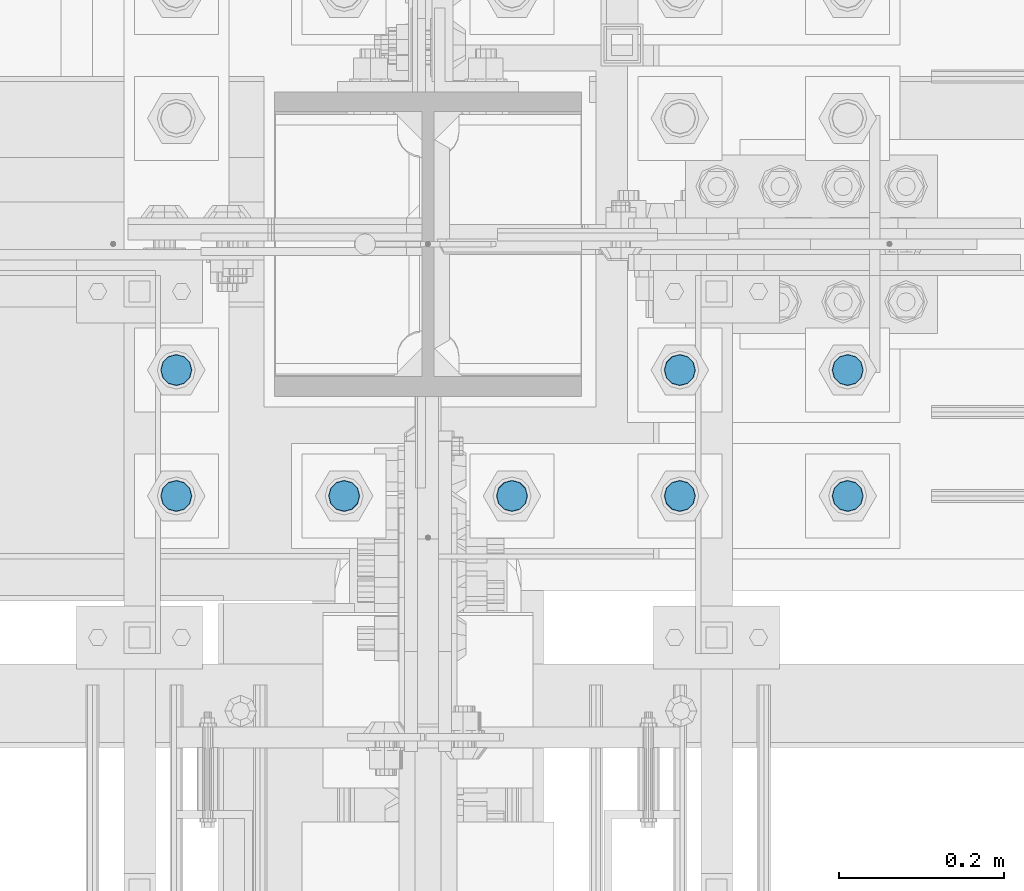
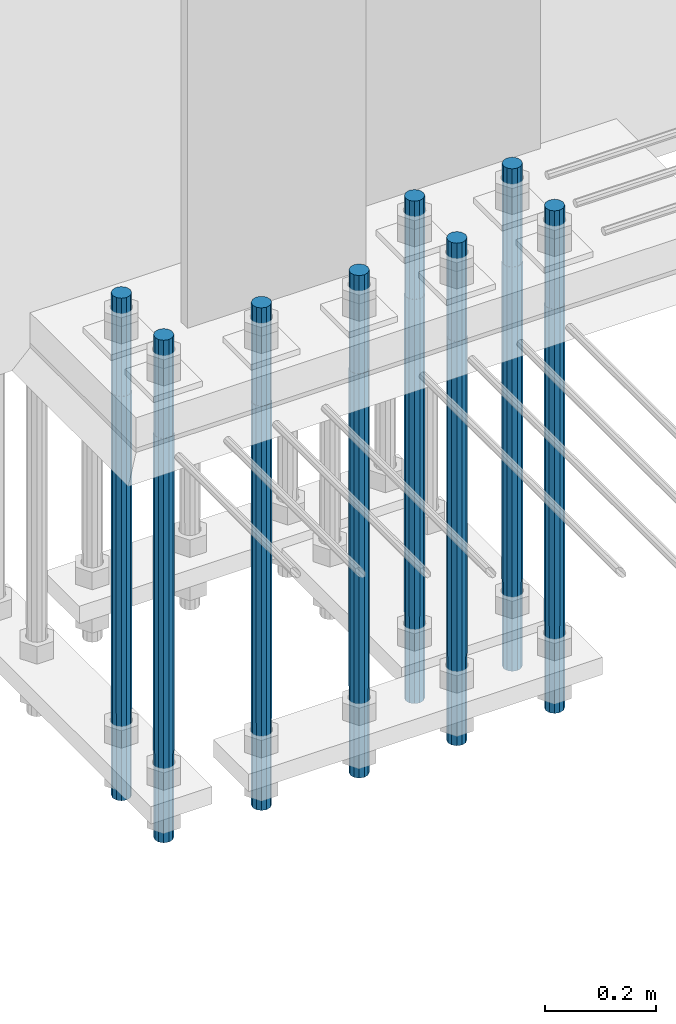
# One storey, part 1305 of 3843: 8 columns, 1 element without a shape of its own.
"""IFC2X3 building model written with IfcOpenShell, lengths in millimetres."""

from ifc_helpers import new_model, si_unit, frame, origin_with_axes, place, context, subcontext, project, spatial, faceted_brep, material, type_object, element, aggregate, save


model = new_model("IFC2X3")

# Units and contexts
model_context = context("Model", 3, precision=1e-05, world=origin_with_axes())
body_context = subcontext(model_context, "Body", "Model", "MODEL_VIEW")
ifc_project = project(units=[si_unit("LENGTHUNIT", "METRE", prefix="MILLI"), si_unit("AREAUNIT", "SQUARE_METRE"), si_unit("VOLUMEUNIT", "CUBIC_METRE"), si_unit("MASSUNIT", "GRAM", prefix="KILO"), si_unit("TIMEUNIT", "SECOND"), si_unit("PLANEANGLEUNIT", "RADIAN"), si_unit("SOLIDANGLEUNIT", "STERADIAN"), si_unit("THERMODYNAMICTEMPERATUREUNIT", "DEGREE_CELSIUS"), si_unit("LUMINOUSINTENSITYUNIT", "LUMEN")], contexts=[model_context])

# Site, building, storey
site_placement = place(None, origin_with_axes())
site = spatial("IfcSite", under=ifc_project, at=site_placement, CompositionType="ELEMENT")
building_placement = place(site_placement, origin_with_axes())
building = spatial("IfcBuilding", under=site, at=building_placement, Name="Undefined", CompositionType="ELEMENT")
storey_placement = place(building_placement, origin_with_axes())
storey = spatial("IfcBuildingStorey", under=building, at=storey_placement, Name="Undefined", CompositionType="ELEMENT", Elevation=0.0)

# Assembly, columns
assembly_placement = place(storey_placement, origin_with_axes())
assembly = element("IfcElementAssembly", 1, at=assembly_placement, inside=storey, Name="TEMPLATE", AssemblyPlace="NOTDEFINED", PredefinedType="RIGID_FRAME")
ifc_material = material(Name="Undefined/F1554-GR.55")
column_type = type_object("IfcColumnType", PredefinedType="NOTDEFINED")
column_1_placement = place(assembly_placement, frame((55626.0, 25311.1, 29565.6), z_axis=(0.0, -1.0, 0.0), x_axis=(0.0, 0.0, -1.0)))
column_1 = element("IfcColumn", 2, at=column_1_placement, type_object=column_type, material=ifc_material, Name="ANCHOR_ROD", context=body_context, shape_type="Brep", body=[
    faceted_brep([(-215.899999999998, -16.0214699700118, 9.25), (-215.899999999998, -9.25, 16.0214699700155), (-215.899999999998, 0.0, 18.5), (-215.899999999998, 9.25, 16.0214699700155), (-215.899999999998, 16.0214699700118, 9.25), (-215.899999999998, 18.5, 0.0), (-215.899999999998, 16.0214699700118, -9.25), (-215.899999999998, 9.25, -16.0214699700155), (-215.899999999998, 0.0, -18.5), (-215.899999999998, -9.25, -16.0214699700155), (-215.899999999998, -16.0214699700118, -9.25), (-215.899999999998, -18.5, 0.0), (0.0, 18.5, 0.0), (0.0, 16.0214699700118, -9.25), (0.0, 9.25, -16.0214699700155), (0.0, 0.0, -18.5), (0.0, -9.25, -16.0214699700155), (0.0, -16.0214699700118, -9.25), (0.0, -18.5, 0.0), (0.0, -16.0214699700118, 9.25), (0.0, -9.25, 16.0214699700155), (0.0, 0.0, 18.5), (0.0, 9.25, 16.0214699700155), (0.0, 16.0214699700118, 9.25), (0.0, -16.4977839420972, 9.52500000000146), (0.0, -9.52500000000146, 16.4977839420972), (0.0, 0.0, 19.0499989999989), (0.0, 9.52500000000146, 16.4977839420972), (0.0, 16.4977839420972, 9.52500000000146), (0.0, 19.0500000000029, 0.0), (0.0, 16.4977839420972, -9.52500000000146), (0.0, 9.52500000000146, -16.4977839420972), (0.0, 0.0, -19.0499989999989), (0.0, -9.52500000000146, -16.4977839420972), (0.0, -16.4977839420972, -9.52500000000146), (0.0, -19.0500000000029, 0.0), (698.5, -19.0499999999993, 0.0), (698.5, -16.4977839420935, 9.52499999999418), (698.5, -9.52500000000146, 16.4977839420899), (698.5, 0.0, 19.0500000000029), (698.5, 9.52500000000146, 16.4977839420899), (698.5, 16.4977839420935, 9.52499999999418), (698.5, 19.0499999999993, 0.0), (698.5, 16.4977839420935, -9.52499999999418), (698.5, 9.52500000000146, -16.4977839420899), (698.5, 0.0, -19.0500000000029), (698.5, -9.52500000000146, -16.4977839420899), (698.5, -16.4977839420935, -9.52499999999418), (698.5, -9.25, 16.0214699700155), (698.5, 0.0, 18.5), (698.5, 9.25, 16.0214699700155), (698.5, 16.0214699700118, 9.25), (698.5, 18.5, 0.0), (698.5, 16.0214699700118, -9.25), (698.5, 9.25, -16.0214699700155), (698.5, 0.0, -18.5), (698.5, -9.25, -16.0214699700155), (698.5, -16.0214699700118, -9.25), (698.5, -18.5, 0.0), (698.5, -16.0214699700118, 9.25), (889.0, -9.25, -16.0214699700155), (889.0, 0.0, -18.5), (889.0, 9.25, -16.0214699700155), (889.0, 16.0214699700118, -9.25), (889.0, 18.5, 0.0), (889.0, 16.0214699700118, 9.25), (889.0, 9.25, 16.0214699700155), (889.0, 0.0, 18.5), (889.0, -9.25, 16.0214699700155), (889.0, -16.0214699700118, 9.25), (889.0, -18.5, 0.0), (889.0, -16.0214699700118, -9.25)], [[[0, 1, 2, 3, 4, 5, 6, 7, 8, 9, 10, 11]], [[6, 5, 12, 13]], [[7, 6, 13, 14]], [[8, 7, 14, 15]], [[9, 8, 15, 16]], [[10, 9, 16, 17]], [[11, 10, 17, 18]], [[0, 11, 18, 19]], [[1, 0, 19, 20]], [[2, 1, 20, 21]], [[3, 2, 21, 22]], [[4, 3, 22, 23]], [[5, 4, 23, 12]], [[24, 25, 26, 27, 28, 29, 30, 31, 32, 33, 34, 35], [22, 21, 20, 19, 18, 17, 16, 15, 14, 13, 12, 23]], [[24, 35, 36, 37]], [[25, 24, 37, 38]], [[26, 25, 38, 39]], [[27, 26, 39, 40]], [[28, 27, 40, 41]], [[29, 28, 41, 42]], [[30, 29, 42, 43]], [[31, 30, 43, 44]], [[32, 31, 44, 45]], [[33, 32, 45, 46]], [[34, 33, 46, 47]], [[35, 34, 47, 36]], [[46, 45, 44, 43, 42, 41, 40, 39, 38, 37, 36, 47], [48, 49, 50, 51, 52, 53, 54, 55, 56, 57, 58, 59]], [[60, 61, 62, 63, 64, 65, 66, 67, 68, 69, 70, 71]], [[68, 67, 49, 48]], [[69, 68, 48, 59]], [[70, 69, 59, 58]], [[71, 70, 58, 57]], [[60, 71, 57, 56]], [[61, 60, 56, 55]], [[62, 61, 55, 54]], [[63, 62, 54, 53]], [[64, 63, 53, 52]], [[65, 64, 52, 51]], [[66, 65, 51, 50]], [[67, 66, 50, 49]]]),
])
column_2_placement = place(assembly_placement, frame((55829.2, 25311.1, 29565.6), z_axis=(0.0, -1.0, 0.0), x_axis=(0.0, 0.0, -1.0)))
column_2 = element("IfcColumn", 3, at=column_2_placement, type_object=column_type, material=ifc_material, Name="ANCHOR_ROD", context=body_context, shape_type="Brep", body=[
    faceted_brep([(-215.899999999998, -16.0214699700118, 9.25), (-215.899999999998, -9.25, 16.0214699700155), (-215.899999999998, 0.0, 18.5), (-215.899999999998, 9.25, 16.0214699700155), (-215.899999999998, 16.0214699700118, 9.25), (-215.899999999998, 18.5, 0.0), (-215.899999999998, 16.0214699700118, -9.25), (-215.899999999998, 9.25, -16.0214699700155), (-215.899999999998, 0.0, -18.5), (-215.899999999998, -9.25, -16.0214699700155), (-215.899999999998, -16.0214699700118, -9.25), (-215.899999999998, -18.5, 0.0), (0.0, 18.5, 0.0), (0.0, 16.0214699700118, -9.25), (0.0, 9.25, -16.0214699700155), (0.0, 0.0, -18.5), (0.0, -9.25, -16.0214699700155), (0.0, -16.0214699700118, -9.25), (0.0, -18.5, 0.0), (0.0, -16.0214699700118, 9.25), (0.0, -9.25, 16.0214699700155), (0.0, 0.0, 18.5), (0.0, 9.25, 16.0214699700155), (0.0, 16.0214699700118, 9.25), (0.0, -16.4977839420972, 9.52500000000146), (0.0, -9.52500000000146, 16.4977839420972), (0.0, 0.0, 19.0499989999989), (0.0, 9.52500000000146, 16.4977839420972), (0.0, 16.4977839420972, 9.52500000000146), (0.0, 19.0500000000029, 0.0), (0.0, 16.4977839420972, -9.52500000000146), (0.0, 9.52500000000146, -16.4977839420972), (0.0, 0.0, -19.0499989999989), (0.0, -9.52500000000146, -16.4977839420972), (0.0, -16.4977839420972, -9.52500000000146), (0.0, -19.0500000000029, 0.0), (698.5, -19.0499999999993, 0.0), (698.5, -16.4977839420935, 9.52499999999418), (698.5, -9.52500000000146, 16.4977839420899), (698.5, 0.0, 19.0500000000029), (698.5, 9.52500000000146, 16.4977839420899), (698.5, 16.4977839420935, 9.52499999999418), (698.5, 19.0499999999993, 0.0), (698.5, 16.4977839420935, -9.52499999999418), (698.5, 9.52500000000146, -16.4977839420899), (698.5, 0.0, -19.0500000000029), (698.5, -9.52500000000146, -16.4977839420899), (698.5, -16.4977839420935, -9.52499999999418), (698.5, -9.25, 16.0214699700155), (698.5, 0.0, 18.5), (698.5, 9.25, 16.0214699700155), (698.5, 16.0214699700118, 9.25), (698.5, 18.5, 0.0), (698.5, 16.0214699700118, -9.25), (698.5, 9.25, -16.0214699700155), (698.5, 0.0, -18.5), (698.5, -9.25, -16.0214699700155), (698.5, -16.0214699700118, -9.25), (698.5, -18.5, 0.0), (698.5, -16.0214699700118, 9.25), (889.0, -9.25, -16.0214699700155), (889.0, 0.0, -18.5), (889.0, 9.25, -16.0214699700155), (889.0, 16.0214699700118, -9.25), (889.0, 18.5, 0.0), (889.0, 16.0214699700118, 9.25), (889.0, 9.25, 16.0214699700155), (889.0, 0.0, 18.5), (889.0, -9.25, 16.0214699700155), (889.0, -16.0214699700118, 9.25), (889.0, -18.5, 0.0), (889.0, -16.0214699700118, -9.25)], [[[0, 1, 2, 3, 4, 5, 6, 7, 8, 9, 10, 11]], [[6, 5, 12, 13]], [[7, 6, 13, 14]], [[8, 7, 14, 15]], [[9, 8, 15, 16]], [[10, 9, 16, 17]], [[11, 10, 17, 18]], [[0, 11, 18, 19]], [[1, 0, 19, 20]], [[2, 1, 20, 21]], [[3, 2, 21, 22]], [[4, 3, 22, 23]], [[5, 4, 23, 12]], [[24, 25, 26, 27, 28, 29, 30, 31, 32, 33, 34, 35], [22, 21, 20, 19, 18, 17, 16, 15, 14, 13, 12, 23]], [[24, 35, 36, 37]], [[25, 24, 37, 38]], [[26, 25, 38, 39]], [[27, 26, 39, 40]], [[28, 27, 40, 41]], [[29, 28, 41, 42]], [[30, 29, 42, 43]], [[31, 30, 43, 44]], [[32, 31, 44, 45]], [[33, 32, 45, 46]], [[34, 33, 46, 47]], [[35, 34, 47, 36]], [[46, 45, 44, 43, 42, 41, 40, 39, 38, 37, 36, 47], [48, 49, 50, 51, 52, 53, 54, 55, 56, 57, 58, 59]], [[60, 61, 62, 63, 64, 65, 66, 67, 68, 69, 70, 71]], [[68, 67, 49, 48]], [[69, 68, 48, 59]], [[70, 69, 59, 58]], [[71, 70, 58, 57]], [[60, 71, 57, 56]], [[61, 60, 56, 55]], [[62, 61, 55, 54]], [[63, 62, 54, 53]], [[64, 63, 53, 52]], [[65, 64, 52, 51]], [[66, 65, 51, 50]], [[67, 66, 50, 49]]]),
])
column_3_placement = place(assembly_placement, frame((56032.4, 25311.1, 29565.6), z_axis=(0.0, -1.0, 0.0), x_axis=(0.0, 0.0, -1.0)))
column_3 = element("IfcColumn", 4, at=column_3_placement, type_object=column_type, material=ifc_material, Name="ANCHOR_ROD", context=body_context, shape_type="Brep", body=[
    faceted_brep([(-215.899999999998, -16.0214699700118, 9.25), (-215.899999999998, -9.25, 16.0214699700155), (-215.899999999998, 0.0, 18.5), (-215.899999999998, 9.25, 16.0214699700155), (-215.899999999998, 16.0214699700118, 9.25), (-215.899999999998, 18.5, 0.0), (-215.899999999998, 16.0214699700118, -9.25), (-215.899999999998, 9.25, -16.0214699700155), (-215.899999999998, 0.0, -18.5), (-215.899999999998, -9.25, -16.0214699700155), (-215.899999999998, -16.0214699700118, -9.25), (-215.899999999998, -18.5, 0.0), (0.0, 18.5, 0.0), (0.0, 16.0214699700118, -9.25), (0.0, 9.25, -16.0214699700155), (0.0, 0.0, -18.5), (0.0, -9.25, -16.0214699700155), (0.0, -16.0214699700118, -9.25), (0.0, -18.5, 0.0), (0.0, -16.0214699700118, 9.25), (0.0, -9.25, 16.0214699700155), (0.0, 0.0, 18.5), (0.0, 9.25, 16.0214699700155), (0.0, 16.0214699700118, 9.25), (0.0, -16.4977839420972, 9.52500000000146), (0.0, -9.52500000000146, 16.4977839420972), (0.0, 0.0, 19.0499989999989), (0.0, 9.52500000000146, 16.4977839420972), (0.0, 16.4977839420972, 9.52500000000146), (0.0, 19.0500000000029, 0.0), (0.0, 16.4977839420972, -9.52500000000146), (0.0, 9.52500000000146, -16.4977839420972), (0.0, 0.0, -19.0499989999989), (0.0, -9.52500000000146, -16.4977839420972), (0.0, -16.4977839420972, -9.52500000000146), (0.0, -19.0500000000029, 0.0), (698.5, -19.0499999999993, 0.0), (698.5, -16.4977839420935, 9.52499999999418), (698.5, -9.52500000000146, 16.4977839420899), (698.5, 0.0, 19.0500000000029), (698.5, 9.52500000000146, 16.4977839420899), (698.5, 16.4977839420935, 9.52499999999418), (698.5, 19.0499999999993, 0.0), (698.5, 16.4977839420935, -9.52499999999418), (698.5, 9.52500000000146, -16.4977839420899), (698.5, 0.0, -19.0500000000029), (698.5, -9.52500000000146, -16.4977839420899), (698.5, -16.4977839420935, -9.52499999999418), (698.5, -9.25, 16.0214699700155), (698.5, 0.0, 18.5), (698.5, 9.25, 16.0214699700155), (698.5, 16.0214699700118, 9.25), (698.5, 18.5, 0.0), (698.5, 16.0214699700118, -9.25), (698.5, 9.25, -16.0214699700155), (698.5, 0.0, -18.5), (698.5, -9.25, -16.0214699700155), (698.5, -16.0214699700118, -9.25), (698.5, -18.5, 0.0), (698.5, -16.0214699700118, 9.25), (889.0, -9.25, -16.0214699700155), (889.0, 0.0, -18.5), (889.0, 9.25, -16.0214699700155), (889.0, 16.0214699700118, -9.25), (889.0, 18.5, 0.0), (889.0, 16.0214699700118, 9.25), (889.0, 9.25, 16.0214699700155), (889.0, 0.0, 18.5), (889.0, -9.25, 16.0214699700155), (889.0, -16.0214699700118, 9.25), (889.0, -18.5, 0.0), (889.0, -16.0214699700118, -9.25)], [[[0, 1, 2, 3, 4, 5, 6, 7, 8, 9, 10, 11]], [[6, 5, 12, 13]], [[7, 6, 13, 14]], [[8, 7, 14, 15]], [[9, 8, 15, 16]], [[10, 9, 16, 17]], [[11, 10, 17, 18]], [[0, 11, 18, 19]], [[1, 0, 19, 20]], [[2, 1, 20, 21]], [[3, 2, 21, 22]], [[4, 3, 22, 23]], [[5, 4, 23, 12]], [[24, 25, 26, 27, 28, 29, 30, 31, 32, 33, 34, 35], [22, 21, 20, 19, 18, 17, 16, 15, 14, 13, 12, 23]], [[24, 35, 36, 37]], [[25, 24, 37, 38]], [[26, 25, 38, 39]], [[27, 26, 39, 40]], [[28, 27, 40, 41]], [[29, 28, 41, 42]], [[30, 29, 42, 43]], [[31, 30, 43, 44]], [[32, 31, 44, 45]], [[33, 32, 45, 46]], [[34, 33, 46, 47]], [[35, 34, 47, 36]], [[46, 45, 44, 43, 42, 41, 40, 39, 38, 37, 36, 47], [48, 49, 50, 51, 52, 53, 54, 55, 56, 57, 58, 59]], [[60, 61, 62, 63, 64, 65, 66, 67, 68, 69, 70, 71]], [[68, 67, 49, 48]], [[69, 68, 48, 59]], [[70, 69, 59, 58]], [[71, 70, 58, 57]], [[60, 71, 57, 56]], [[61, 60, 56, 55]], [[62, 61, 55, 54]], [[63, 62, 54, 53]], [[64, 63, 53, 52]], [[65, 64, 52, 51]], [[66, 65, 51, 50]], [[67, 66, 50, 49]]]),
])
column_4_placement = place(assembly_placement, frame((56235.6, 25311.1, 29565.6), z_axis=(0.0, 1.0, 0.0), x_axis=(0.0, 0.0, -1.0)))
column_4 = element("IfcColumn", 5, at=column_4_placement, type_object=column_type, material=ifc_material, Name="ANCHOR_ROD", context=body_context, shape_type="Brep", body=[
    faceted_brep([(-215.899999999998, -16.0214699700118, 9.25), (-215.899999999998, -9.25, 16.0214699700155), (-215.899999999998, 0.0, 18.5), (-215.899999999998, 9.25, 16.0214699700155), (-215.899999999998, 16.0214699700118, 9.25), (-215.899999999998, 18.5, 0.0), (-215.899999999998, 16.0214699700118, -9.25), (-215.899999999998, 9.25, -16.0214699700155), (-215.899999999998, 0.0, -18.5), (-215.899999999998, -9.25, -16.0214699700155), (-215.899999999998, -16.0214699700118, -9.25), (-215.899999999998, -18.5, 0.0), (0.0, 18.5, 0.0), (0.0, 16.0214699700118, -9.25), (0.0, 9.25, -16.0214699700155), (0.0, 0.0, -18.5), (0.0, -9.25, -16.0214699700155), (0.0, -16.0214699700118, -9.25), (0.0, -18.5, 0.0), (0.0, -16.0214699700118, 9.25), (0.0, -9.25, 16.0214699700155), (0.0, 0.0, 18.5), (0.0, 9.25, 16.0214699700155), (0.0, 16.0214699700118, 9.25), (0.0, -16.4977839420972, 9.52500000000146), (0.0, -9.52500000000146, 16.4977839420972), (0.0, 0.0, 19.0499989999989), (0.0, 9.52500000000146, 16.4977839420972), (0.0, 16.4977839420972, 9.52500000000146), (0.0, 19.0500000000029, 0.0), (0.0, 16.4977839420972, -9.52500000000146), (0.0, 9.52500000000146, -16.4977839420972), (0.0, 0.0, -19.0499989999989), (0.0, -9.52500000000146, -16.4977839420972), (0.0, -16.4977839420972, -9.52500000000146), (0.0, -19.0500000000029, 0.0), (698.5, -19.0499999999993, 0.0), (698.5, -16.4977839420935, 9.52499999999418), (698.5, -9.52500000000146, 16.4977839420899), (698.5, 0.0, 19.0500000000029), (698.5, 9.52500000000146, 16.4977839420899), (698.5, 16.4977839420935, 9.52499999999418), (698.5, 19.0499999999993, 0.0), (698.5, 16.4977839420935, -9.52499999999418), (698.5, 9.52500000000146, -16.4977839420899), (698.5, 0.0, -19.0500000000029), (698.5, -9.52500000000146, -16.4977839420899), (698.5, -16.4977839420935, -9.52499999999418), (698.5, -9.25, 16.0214699700155), (698.5, 0.0, 18.5), (698.5, 9.25, 16.0214699700155), (698.5, 16.0214699700118, 9.25), (698.5, 18.5, 0.0), (698.5, 16.0214699700118, -9.25), (698.5, 9.25, -16.0214699700155), (698.5, 0.0, -18.5), (698.5, -9.25, -16.0214699700155), (698.5, -16.0214699700118, -9.25), (698.5, -18.5, 0.0), (698.5, -16.0214699700118, 9.25), (889.0, -9.25, -16.0214699700155), (889.0, 0.0, -18.5), (889.0, 9.25, -16.0214699700155), (889.0, 16.0214699700118, -9.25), (889.0, 18.5, 0.0), (889.0, 16.0214699700118, 9.25), (889.0, 9.25, 16.0214699700155), (889.0, 0.0, 18.5), (889.0, -9.25, 16.0214699700155), (889.0, -16.0214699700118, 9.25), (889.0, -18.5, 0.0), (889.0, -16.0214699700118, -9.25)], [[[0, 1, 2, 3, 4, 5, 6, 7, 8, 9, 10, 11]], [[6, 5, 12, 13]], [[7, 6, 13, 14]], [[8, 7, 14, 15]], [[9, 8, 15, 16]], [[10, 9, 16, 17]], [[11, 10, 17, 18]], [[0, 11, 18, 19]], [[1, 0, 19, 20]], [[2, 1, 20, 21]], [[3, 2, 21, 22]], [[4, 3, 22, 23]], [[5, 4, 23, 12]], [[24, 25, 26, 27, 28, 29, 30, 31, 32, 33, 34, 35], [22, 21, 20, 19, 18, 17, 16, 15, 14, 13, 12, 23]], [[24, 35, 36, 37]], [[25, 24, 37, 38]], [[26, 25, 38, 39]], [[27, 26, 39, 40]], [[28, 27, 40, 41]], [[29, 28, 41, 42]], [[30, 29, 42, 43]], [[31, 30, 43, 44]], [[32, 31, 44, 45]], [[33, 32, 45, 46]], [[34, 33, 46, 47]], [[35, 34, 47, 36]], [[46, 45, 44, 43, 42, 41, 40, 39, 38, 37, 36, 47], [48, 49, 50, 51, 52, 53, 54, 55, 56, 57, 58, 59]], [[60, 61, 62, 63, 64, 65, 66, 67, 68, 69, 70, 71]], [[68, 67, 49, 48]], [[69, 68, 48, 59]], [[70, 69, 59, 58]], [[71, 70, 58, 57]], [[60, 71, 57, 56]], [[61, 60, 56, 55]], [[62, 61, 55, 54]], [[63, 62, 54, 53]], [[64, 63, 53, 52]], [[65, 64, 52, 51]], [[66, 65, 51, 50]], [[67, 66, 50, 49]]]),
])
column_5_placement = place(assembly_placement, frame((56438.8, 25311.1, 29565.6), z_axis=(0.0, 1.0, 0.0), x_axis=(0.0, 0.0, -1.0)))
column_5 = element("IfcColumn", 6, at=column_5_placement, type_object=column_type, material=ifc_material, Name="ANCHOR_ROD", context=body_context, shape_type="Brep", body=[
    faceted_brep([(-215.899999999998, -16.0214699700118, 9.25), (-215.899999999998, -9.25, 16.0214699700155), (-215.899999999998, 0.0, 18.5), (-215.899999999998, 9.25, 16.0214699700155), (-215.899999999998, 16.0214699700118, 9.25), (-215.899999999998, 18.5, 0.0), (-215.899999999998, 16.0214699700118, -9.25), (-215.899999999998, 9.25, -16.0214699700155), (-215.899999999998, 0.0, -18.5), (-215.899999999998, -9.25, -16.0214699700155), (-215.899999999998, -16.0214699700118, -9.25), (-215.899999999998, -18.5, 0.0), (0.0, 18.5, 0.0), (0.0, 16.0214699700118, -9.25), (0.0, 9.25, -16.0214699700155), (0.0, 0.0, -18.5), (0.0, -9.25, -16.0214699700155), (0.0, -16.0214699700118, -9.25), (0.0, -18.5, 0.0), (0.0, -16.0214699700118, 9.25), (0.0, -9.25, 16.0214699700155), (0.0, 0.0, 18.5), (0.0, 9.25, 16.0214699700155), (0.0, 16.0214699700118, 9.25), (0.0, -16.4977839420972, 9.52500000000146), (0.0, -9.52500000000146, 16.4977839420972), (0.0, 0.0, 19.0499989999989), (0.0, 9.52500000000146, 16.4977839420972), (0.0, 16.4977839420972, 9.52500000000146), (0.0, 19.0500000000029, 0.0), (0.0, 16.4977839420972, -9.52500000000146), (0.0, 9.52500000000146, -16.4977839420972), (0.0, 0.0, -19.0499989999989), (0.0, -9.52500000000146, -16.4977839420972), (0.0, -16.4977839420972, -9.52500000000146), (0.0, -19.0500000000029, 0.0), (698.5, -19.0499999999993, 0.0), (698.5, -16.4977839420935, 9.52499999999418), (698.5, -9.52500000000146, 16.4977839420899), (698.5, 0.0, 19.0500000000029), (698.5, 9.52500000000146, 16.4977839420899), (698.5, 16.4977839420935, 9.52499999999418), (698.5, 19.0499999999993, 0.0), (698.5, 16.4977839420935, -9.52499999999418), (698.5, 9.52500000000146, -16.4977839420899), (698.5, 0.0, -19.0500000000029), (698.5, -9.52500000000146, -16.4977839420899), (698.5, -16.4977839420935, -9.52499999999418), (698.5, -9.25, 16.0214699700155), (698.5, 0.0, 18.5), (698.5, 9.25, 16.0214699700155), (698.5, 16.0214699700118, 9.25), (698.5, 18.5, 0.0), (698.5, 16.0214699700118, -9.25), (698.5, 9.25, -16.0214699700155), (698.5, 0.0, -18.5), (698.5, -9.25, -16.0214699700155), (698.5, -16.0214699700118, -9.25), (698.5, -18.5, 0.0), (698.5, -16.0214699700118, 9.25), (889.0, -9.25, -16.0214699700155), (889.0, 0.0, -18.5), (889.0, 9.25, -16.0214699700155), (889.0, 16.0214699700118, -9.25), (889.0, 18.5, 0.0), (889.0, 16.0214699700118, 9.25), (889.0, 9.25, 16.0214699700155), (889.0, 0.0, 18.5), (889.0, -9.25, 16.0214699700155), (889.0, -16.0214699700118, 9.25), (889.0, -18.5, 0.0), (889.0, -16.0214699700118, -9.25)], [[[0, 1, 2, 3, 4, 5, 6, 7, 8, 9, 10, 11]], [[6, 5, 12, 13]], [[7, 6, 13, 14]], [[8, 7, 14, 15]], [[9, 8, 15, 16]], [[10, 9, 16, 17]], [[11, 10, 17, 18]], [[0, 11, 18, 19]], [[1, 0, 19, 20]], [[2, 1, 20, 21]], [[3, 2, 21, 22]], [[4, 3, 22, 23]], [[5, 4, 23, 12]], [[24, 25, 26, 27, 28, 29, 30, 31, 32, 33, 34, 35], [22, 21, 20, 19, 18, 17, 16, 15, 14, 13, 12, 23]], [[24, 35, 36, 37]], [[25, 24, 37, 38]], [[26, 25, 38, 39]], [[27, 26, 39, 40]], [[28, 27, 40, 41]], [[29, 28, 41, 42]], [[30, 29, 42, 43]], [[31, 30, 43, 44]], [[32, 31, 44, 45]], [[33, 32, 45, 46]], [[34, 33, 46, 47]], [[35, 34, 47, 36]], [[46, 45, 44, 43, 42, 41, 40, 39, 38, 37, 36, 47], [48, 49, 50, 51, 52, 53, 54, 55, 56, 57, 58, 59]], [[60, 61, 62, 63, 64, 65, 66, 67, 68, 69, 70, 71]], [[68, 67, 49, 48]], [[69, 68, 48, 59]], [[70, 69, 59, 58]], [[71, 70, 58, 57]], [[60, 71, 57, 56]], [[61, 60, 56, 55]], [[62, 61, 55, 54]], [[63, 62, 54, 53]], [[64, 63, 53, 52]], [[65, 64, 52, 51]], [[66, 65, 51, 50]], [[67, 66, 50, 49]]]),
])
column_6_placement = place(assembly_placement, frame((55626.0, 25463.5, 29565.6), z_axis=(0.0, -1.0, 0.0), x_axis=(0.0, 0.0, -1.0)))
column_6 = element("IfcColumn", 7, at=column_6_placement, type_object=column_type, material=ifc_material, Name="ANCHOR_ROD", context=body_context, shape_type="Brep", body=[
    faceted_brep([(-215.899999999998, -16.0214699700118, 9.25), (-215.899999999998, -9.25, 16.0214699700155), (-215.899999999998, 0.0, 18.5), (-215.899999999998, 9.25, 16.0214699700155), (-215.899999999998, 16.0214699700118, 9.25), (-215.899999999998, 18.5, 0.0), (-215.899999999998, 16.0214699700118, -9.25), (-215.899999999998, 9.25, -16.0214699700155), (-215.899999999998, 0.0, -18.5), (-215.899999999998, -9.25, -16.0214699700155), (-215.899999999998, -16.0214699700118, -9.25), (-215.899999999998, -18.5, 0.0), (0.0, 18.5, 0.0), (0.0, 16.0214699700118, -9.25), (0.0, 9.25, -16.0214699700155), (0.0, 0.0, -18.5), (0.0, -9.25, -16.0214699700155), (0.0, -16.0214699700118, -9.25), (0.0, -18.5, 0.0), (0.0, -16.0214699700118, 9.25), (0.0, -9.25, 16.0214699700155), (0.0, 0.0, 18.5), (0.0, 9.25, 16.0214699700155), (0.0, 16.0214699700118, 9.25), (0.0, -16.4977839420972, 9.52500000000146), (0.0, -9.52500000000146, 16.4977839420972), (0.0, 0.0, 19.0499989999989), (0.0, 9.52500000000146, 16.4977839420972), (0.0, 16.4977839420972, 9.52500000000146), (0.0, 19.0500000000029, 0.0), (0.0, 16.4977839420972, -9.52500000000146), (0.0, 9.52500000000146, -16.4977839420972), (0.0, 0.0, -19.0499989999989), (0.0, -9.52500000000146, -16.4977839420972), (0.0, -16.4977839420972, -9.52500000000146), (0.0, -19.0500000000029, 0.0), (698.5, -19.0499999999993, 0.0), (698.5, -16.4977839420935, 9.52499999999418), (698.5, -9.52500000000146, 16.4977839420899), (698.5, 0.0, 19.0500000000029), (698.5, 9.52500000000146, 16.4977839420899), (698.5, 16.4977839420935, 9.52499999999418), (698.5, 19.0499999999993, 0.0), (698.5, 16.4977839420935, -9.52499999999418), (698.5, 9.52500000000146, -16.4977839420899), (698.5, 0.0, -19.0500000000029), (698.5, -9.52500000000146, -16.4977839420899), (698.5, -16.4977839420935, -9.52499999999418), (698.5, -9.25, 16.0214699700155), (698.5, 0.0, 18.5), (698.5, 9.25, 16.0214699700155), (698.5, 16.0214699700118, 9.25), (698.5, 18.5, 0.0), (698.5, 16.0214699700118, -9.25), (698.5, 9.25, -16.0214699700155), (698.5, 0.0, -18.5), (698.5, -9.25, -16.0214699700155), (698.5, -16.0214699700118, -9.25), (698.5, -18.5, 0.0), (698.5, -16.0214699700118, 9.25), (889.0, -9.25, -16.0214699700155), (889.0, 0.0, -18.5), (889.0, 9.25, -16.0214699700155), (889.0, 16.0214699700118, -9.25), (889.0, 18.5, 0.0), (889.0, 16.0214699700118, 9.25), (889.0, 9.25, 16.0214699700155), (889.0, 0.0, 18.5), (889.0, -9.25, 16.0214699700155), (889.0, -16.0214699700118, 9.25), (889.0, -18.5, 0.0), (889.0, -16.0214699700118, -9.25)], [[[0, 1, 2, 3, 4, 5, 6, 7, 8, 9, 10, 11]], [[6, 5, 12, 13]], [[7, 6, 13, 14]], [[8, 7, 14, 15]], [[9, 8, 15, 16]], [[10, 9, 16, 17]], [[11, 10, 17, 18]], [[0, 11, 18, 19]], [[1, 0, 19, 20]], [[2, 1, 20, 21]], [[3, 2, 21, 22]], [[4, 3, 22, 23]], [[5, 4, 23, 12]], [[24, 25, 26, 27, 28, 29, 30, 31, 32, 33, 34, 35], [22, 21, 20, 19, 18, 17, 16, 15, 14, 13, 12, 23]], [[24, 35, 36, 37]], [[25, 24, 37, 38]], [[26, 25, 38, 39]], [[27, 26, 39, 40]], [[28, 27, 40, 41]], [[29, 28, 41, 42]], [[30, 29, 42, 43]], [[31, 30, 43, 44]], [[32, 31, 44, 45]], [[33, 32, 45, 46]], [[34, 33, 46, 47]], [[35, 34, 47, 36]], [[46, 45, 44, 43, 42, 41, 40, 39, 38, 37, 36, 47], [48, 49, 50, 51, 52, 53, 54, 55, 56, 57, 58, 59]], [[60, 61, 62, 63, 64, 65, 66, 67, 68, 69, 70, 71]], [[68, 67, 49, 48]], [[69, 68, 48, 59]], [[70, 69, 59, 58]], [[71, 70, 58, 57]], [[60, 71, 57, 56]], [[61, 60, 56, 55]], [[62, 61, 55, 54]], [[63, 62, 54, 53]], [[64, 63, 53, 52]], [[65, 64, 52, 51]], [[66, 65, 51, 50]], [[67, 66, 50, 49]]]),
])
column_7_placement = place(assembly_placement, frame((56235.6, 25463.5, 29565.6), z_axis=(0.0, 1.0, 0.0), x_axis=(0.0, 0.0, -1.0)))
column_7 = element("IfcColumn", 8, at=column_7_placement, type_object=column_type, material=ifc_material, Name="ANCHOR_ROD", context=body_context, shape_type="Brep", body=[
    faceted_brep([(-215.899999999998, -16.0214699700118, 9.25), (-215.899999999998, -9.25, 16.0214699700155), (-215.899999999998, 0.0, 18.5), (-215.899999999998, 9.25, 16.0214699700155), (-215.899999999998, 16.0214699700118, 9.25), (-215.899999999998, 18.5, 0.0), (-215.899999999998, 16.0214699700118, -9.25), (-215.899999999998, 9.25, -16.0214699700155), (-215.899999999998, 0.0, -18.5), (-215.899999999998, -9.25, -16.0214699700155), (-215.899999999998, -16.0214699700118, -9.25), (-215.899999999998, -18.5, 0.0), (0.0, 18.5, 0.0), (0.0, 16.0214699700118, -9.25), (0.0, 9.25, -16.0214699700155), (0.0, 0.0, -18.5), (0.0, -9.25, -16.0214699700155), (0.0, -16.0214699700118, -9.25), (0.0, -18.5, 0.0), (0.0, -16.0214699700118, 9.25), (0.0, -9.25, 16.0214699700155), (0.0, 0.0, 18.5), (0.0, 9.25, 16.0214699700155), (0.0, 16.0214699700118, 9.25), (0.0, -16.4977839420972, 9.52500000000146), (0.0, -9.52500000000146, 16.4977839420972), (0.0, 0.0, 19.0499989999989), (0.0, 9.52500000000146, 16.4977839420972), (0.0, 16.4977839420972, 9.52500000000146), (0.0, 19.0500000000029, 0.0), (0.0, 16.4977839420972, -9.52500000000146), (0.0, 9.52500000000146, -16.4977839420972), (0.0, 0.0, -19.0499989999989), (0.0, -9.52500000000146, -16.4977839420972), (0.0, -16.4977839420972, -9.52500000000146), (0.0, -19.0500000000029, 0.0), (698.5, -19.0499999999993, 0.0), (698.5, -16.4977839420935, 9.52499999999418), (698.5, -9.52500000000146, 16.4977839420899), (698.5, 0.0, 19.0500000000029), (698.5, 9.52500000000146, 16.4977839420899), (698.5, 16.4977839420935, 9.52499999999418), (698.5, 19.0499999999993, 0.0), (698.5, 16.4977839420935, -9.52499999999418), (698.5, 9.52500000000146, -16.4977839420899), (698.5, 0.0, -19.0500000000029), (698.5, -9.52500000000146, -16.4977839420899), (698.5, -16.4977839420935, -9.52499999999418), (698.5, -9.25, 16.0214699700155), (698.5, 0.0, 18.5), (698.5, 9.25, 16.0214699700155), (698.5, 16.0214699700118, 9.25), (698.5, 18.5, 0.0), (698.5, 16.0214699700118, -9.25), (698.5, 9.25, -16.0214699700155), (698.5, 0.0, -18.5), (698.5, -9.25, -16.0214699700155), (698.5, -16.0214699700118, -9.25), (698.5, -18.5, 0.0), (698.5, -16.0214699700118, 9.25), (889.0, -9.25, -16.0214699700155), (889.0, 0.0, -18.5), (889.0, 9.25, -16.0214699700155), (889.0, 16.0214699700118, -9.25), (889.0, 18.5, 0.0), (889.0, 16.0214699700118, 9.25), (889.0, 9.25, 16.0214699700155), (889.0, 0.0, 18.5), (889.0, -9.25, 16.0214699700155), (889.0, -16.0214699700118, 9.25), (889.0, -18.5, 0.0), (889.0, -16.0214699700118, -9.25)], [[[0, 1, 2, 3, 4, 5, 6, 7, 8, 9, 10, 11]], [[6, 5, 12, 13]], [[7, 6, 13, 14]], [[8, 7, 14, 15]], [[9, 8, 15, 16]], [[10, 9, 16, 17]], [[11, 10, 17, 18]], [[0, 11, 18, 19]], [[1, 0, 19, 20]], [[2, 1, 20, 21]], [[3, 2, 21, 22]], [[4, 3, 22, 23]], [[5, 4, 23, 12]], [[24, 25, 26, 27, 28, 29, 30, 31, 32, 33, 34, 35], [22, 21, 20, 19, 18, 17, 16, 15, 14, 13, 12, 23]], [[24, 35, 36, 37]], [[25, 24, 37, 38]], [[26, 25, 38, 39]], [[27, 26, 39, 40]], [[28, 27, 40, 41]], [[29, 28, 41, 42]], [[30, 29, 42, 43]], [[31, 30, 43, 44]], [[32, 31, 44, 45]], [[33, 32, 45, 46]], [[34, 33, 46, 47]], [[35, 34, 47, 36]], [[46, 45, 44, 43, 42, 41, 40, 39, 38, 37, 36, 47], [48, 49, 50, 51, 52, 53, 54, 55, 56, 57, 58, 59]], [[60, 61, 62, 63, 64, 65, 66, 67, 68, 69, 70, 71]], [[68, 67, 49, 48]], [[69, 68, 48, 59]], [[70, 69, 59, 58]], [[71, 70, 58, 57]], [[60, 71, 57, 56]], [[61, 60, 56, 55]], [[62, 61, 55, 54]], [[63, 62, 54, 53]], [[64, 63, 53, 52]], [[65, 64, 52, 51]], [[66, 65, 51, 50]], [[67, 66, 50, 49]]]),
])
column_8_placement = place(assembly_placement, frame((56438.8, 25463.5, 29565.6), z_axis=(0.0, 1.0, 0.0), x_axis=(0.0, 0.0, -1.0)))
column_8 = element("IfcColumn", 9, at=column_8_placement, type_object=column_type, material=ifc_material, Name="ANCHOR_ROD", context=body_context, shape_type="Brep", body=[
    faceted_brep([(-215.899999999998, -16.0214699700118, 9.25), (-215.899999999998, -9.25, 16.0214699700155), (-215.899999999998, 0.0, 18.5), (-215.899999999998, 9.25, 16.0214699700155), (-215.899999999998, 16.0214699700118, 9.25), (-215.899999999998, 18.5, 0.0), (-215.899999999998, 16.0214699700118, -9.25), (-215.899999999998, 9.25, -16.0214699700155), (-215.899999999998, 0.0, -18.5), (-215.899999999998, -9.25, -16.0214699700155), (-215.899999999998, -16.0214699700118, -9.25), (-215.899999999998, -18.5, 0.0), (0.0, 18.5, 0.0), (0.0, 16.0214699700118, -9.25), (0.0, 9.25, -16.0214699700155), (0.0, 0.0, -18.5), (0.0, -9.25, -16.0214699700155), (0.0, -16.0214699700118, -9.25), (0.0, -18.5, 0.0), (0.0, -16.0214699700118, 9.25), (0.0, -9.25, 16.0214699700155), (0.0, 0.0, 18.5), (0.0, 9.25, 16.0214699700155), (0.0, 16.0214699700118, 9.25), (0.0, -16.4977839420972, 9.52500000000146), (0.0, -9.52500000000146, 16.4977839420972), (0.0, 0.0, 19.0499989999989), (0.0, 9.52500000000146, 16.4977839420972), (0.0, 16.4977839420972, 9.52500000000146), (0.0, 19.0500000000029, 0.0), (0.0, 16.4977839420972, -9.52500000000146), (0.0, 9.52500000000146, -16.4977839420972), (0.0, 0.0, -19.0499989999989), (0.0, -9.52500000000146, -16.4977839420972), (0.0, -16.4977839420972, -9.52500000000146), (0.0, -19.0500000000029, 0.0), (698.5, -19.0499999999993, 0.0), (698.5, -16.4977839420935, 9.52499999999418), (698.5, -9.52500000000146, 16.4977839420899), (698.5, 0.0, 19.0500000000029), (698.5, 9.52500000000146, 16.4977839420899), (698.5, 16.4977839420935, 9.52499999999418), (698.5, 19.0499999999993, 0.0), (698.5, 16.4977839420935, -9.52499999999418), (698.5, 9.52500000000146, -16.4977839420899), (698.5, 0.0, -19.0500000000029), (698.5, -9.52500000000146, -16.4977839420899), (698.5, -16.4977839420935, -9.52499999999418), (698.5, -9.25, 16.0214699700155), (698.5, 0.0, 18.5), (698.5, 9.25, 16.0214699700155), (698.5, 16.0214699700118, 9.25), (698.5, 18.5, 0.0), (698.5, 16.0214699700118, -9.25), (698.5, 9.25, -16.0214699700155), (698.5, 0.0, -18.5), (698.5, -9.25, -16.0214699700155), (698.5, -16.0214699700118, -9.25), (698.5, -18.5, 0.0), (698.5, -16.0214699700118, 9.25), (889.0, -9.25, -16.0214699700155), (889.0, 0.0, -18.5), (889.0, 9.25, -16.0214699700155), (889.0, 16.0214699700118, -9.25), (889.0, 18.5, 0.0), (889.0, 16.0214699700118, 9.25), (889.0, 9.25, 16.0214699700155), (889.0, 0.0, 18.5), (889.0, -9.25, 16.0214699700155), (889.0, -16.0214699700118, 9.25), (889.0, -18.5, 0.0), (889.0, -16.0214699700118, -9.25)], [[[0, 1, 2, 3, 4, 5, 6, 7, 8, 9, 10, 11]], [[6, 5, 12, 13]], [[7, 6, 13, 14]], [[8, 7, 14, 15]], [[9, 8, 15, 16]], [[10, 9, 16, 17]], [[11, 10, 17, 18]], [[0, 11, 18, 19]], [[1, 0, 19, 20]], [[2, 1, 20, 21]], [[3, 2, 21, 22]], [[4, 3, 22, 23]], [[5, 4, 23, 12]], [[24, 25, 26, 27, 28, 29, 30, 31, 32, 33, 34, 35], [22, 21, 20, 19, 18, 17, 16, 15, 14, 13, 12, 23]], [[24, 35, 36, 37]], [[25, 24, 37, 38]], [[26, 25, 38, 39]], [[27, 26, 39, 40]], [[28, 27, 40, 41]], [[29, 28, 41, 42]], [[30, 29, 42, 43]], [[31, 30, 43, 44]], [[32, 31, 44, 45]], [[33, 32, 45, 46]], [[34, 33, 46, 47]], [[35, 34, 47, 36]], [[46, 45, 44, 43, 42, 41, 40, 39, 38, 37, 36, 47], [48, 49, 50, 51, 52, 53, 54, 55, 56, 57, 58, 59]], [[60, 61, 62, 63, 64, 65, 66, 67, 68, 69, 70, 71]], [[68, 67, 49, 48]], [[69, 68, 48, 59]], [[70, 69, 59, 58]], [[71, 70, 58, 57]], [[60, 71, 57, 56]], [[61, 60, 56, 55]], [[62, 61, 55, 54]], [[63, 62, 54, 53]], [[64, 63, 53, 52]], [[65, 64, 52, 51]], [[66, 65, 51, 50]], [[67, 66, 50, 49]]]),
])
aggregate(assembly, [column_1, column_2, column_3, column_4, column_5, column_6, column_7, column_8])

save(model, "model.ifc")
